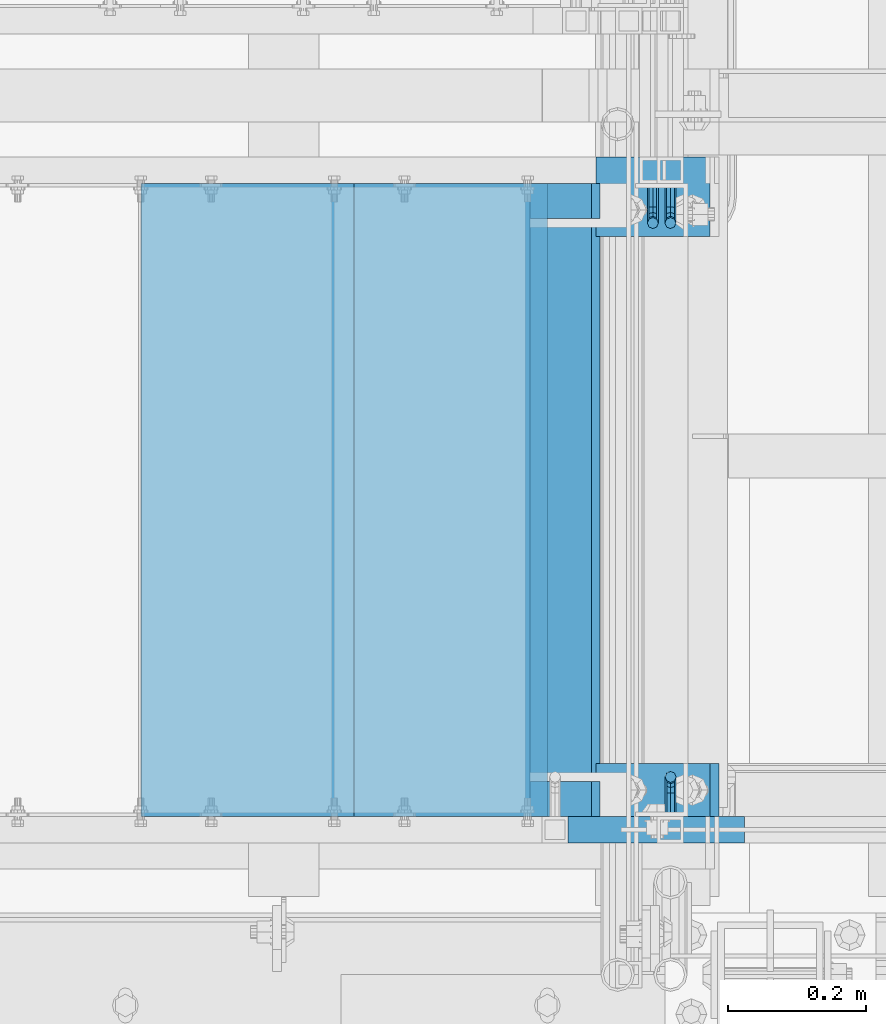
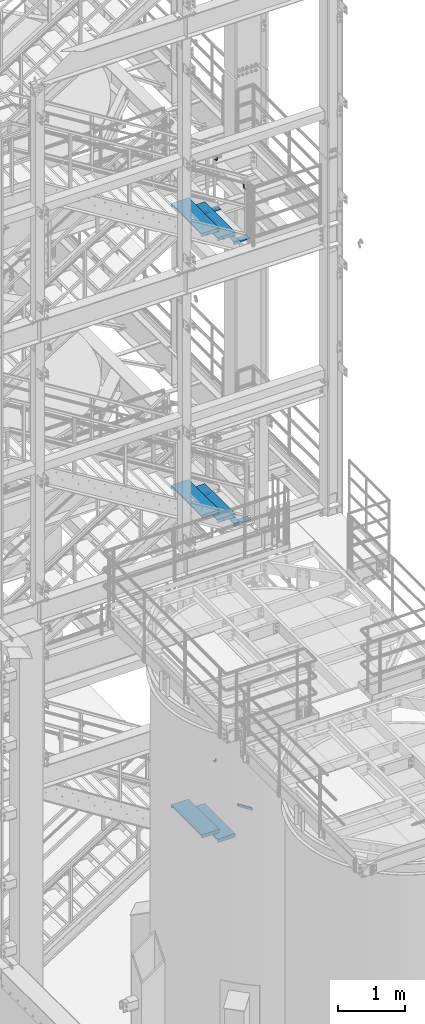
# One storey, part 1155 of 1876: 18 beams, 1 member, 7 elements without a shape of their own.
"""IFC2X3 building model written with IfcOpenShell, lengths in millimetres."""

from ifc_helpers import new_model, si_unit, frame, origin_with_axes, place, context, subcontext, project, spatial, faceted_brep, material, type_object, element, aggregate, save


model = new_model("IFC2X3")

# Units and contexts
model_context = context("Model", 3, precision=1e-05, world=origin_with_axes())
body_context = subcontext(model_context, "Body", "Model", "MODEL_VIEW")
ifc_project = project(units=[si_unit("LENGTHUNIT", "METRE", prefix="MILLI"), si_unit("AREAUNIT", "SQUARE_METRE"), si_unit("VOLUMEUNIT", "CUBIC_METRE"), si_unit("MASSUNIT", "GRAM", prefix="KILO"), si_unit("TIMEUNIT", "SECOND"), si_unit("PLANEANGLEUNIT", "RADIAN"), si_unit("SOLIDANGLEUNIT", "STERADIAN"), si_unit("THERMODYNAMICTEMPERATUREUNIT", "DEGREE_CELSIUS"), si_unit("LUMINOUSINTENSITYUNIT", "LUMEN")], contexts=[model_context])

# Site, building, storey
site_placement = place(None, origin_with_axes())
site = spatial("IfcSite", under=ifc_project, at=site_placement, CompositionType="ELEMENT")
building_placement = place(site_placement, origin_with_axes())
building = spatial("IfcBuilding", under=site, at=building_placement, Name="Undefined", CompositionType="ELEMENT")
storey_placement = place(building_placement, origin_with_axes())
storey = spatial("IfcBuildingStorey", under=building, at=storey_placement, Name="Undefined", CompositionType="ELEMENT", Elevation=0.0)

# Assembly, beam
assembly_1_placement = place(storey_placement, origin_with_axes())
assembly_1 = element("IfcElementAssembly", 1, at=assembly_1_placement, inside=storey, Name="STRINGER", AssemblyPlace="NOTDEFINED", PredefinedType="RIGID_FRAME")
ifc_material_1 = material(Name="STEEL/A36")
beam_type_1 = type_object("IfcBeamType", PredefinedType="NOTDEFINED")
beam_1_placement = place(assembly_1_placement, frame((6121.39999694572, -5975.34987682352, 8159.75000058556), z_axis=(-1.0, 0.0, 0.0), x_axis=(0.0, -1.0, 0.0)))
beam_1 = element("IfcBeam", 2, at=beam_1_placement, type_object=beam_type_1, material=ifc_material_1, Name="PLATE", context=body_context, shape_type="Brep", body=[
    faceted_brep([(0.0, 3.17500000000018, -50.8000000000002), (0.0, 3.17500000000018, 50.8000000000002), (901.700000190736, 3.17500000000018, 50.8000000000002), (901.700000190736, 3.17500000000018, -50.8000000000002), (0.0, -3.17500000000018, 50.8000000000002), (901.700000190736, -3.17500000000018, 50.8000000000002), (0.0, -3.17500000000018, -50.8000000000002), (901.700000190736, -3.17500000000018, -50.8000000000002)], [[[0, 1, 2, 3]], [[1, 4, 5, 2]], [[4, 6, 7, 5]], [[6, 0, 3, 7]], [[5, 7, 3, 2]], [[6, 4, 1, 0]]]),
])

assembly_2_placement = place(storey_placement, origin_with_axes())
assembly_2 = element("IfcElementAssembly", 3, at=assembly_2_placement, inside=storey, Name="RAIL", AssemblyPlace="NOTDEFINED", PredefinedType="RIGID_FRAME")
beam_type_2 = type_object("IfcBeamType", PredefinedType="NOTDEFINED")
beam_2_placement = place(assembly_2_placement, frame((6273.79999407512, -5969.00000114554, 14207.5691203889), z_axis=(-1.0, 0.0, 0.0), x_axis=(0.0, -1.0, 0.0)))
beam_2 = element("IfcBeam", 4, at=beam_2_placement, type_object=beam_type_2, material=ifc_material_1, Name="BRACKET", context=body_context, shape_type="Brep", body=[
    faceted_brep([(0.0, -5.61266007566822, 5.61266007566883), (0.0, 0.0, 7.9375), (0.0, 5.61266007566822, 5.61266007566883), (0.0, 7.9375, 0.0), (0.0, 5.61266007566822, -5.61266007566883), (0.0, 0.0, -7.9375), (0.0, -5.61266007566822, -5.61266007566883), (0.0, -7.9375, 0.0), (23.8125, -5.61266007566883, -5.61266007566792), (23.8125, -7.9375, 0.0), (23.8125, -5.61266007566883, 5.61266007566792), (23.8125, 0.0, 7.9375), (23.8125, 5.61266007566883, 5.61266007566792), (23.8125, 7.9375, 0.0), (23.8125, 5.61266007566883, -5.61266007566792), (23.8125, 0.0, -7.9375), (36.5702095103998, 2.53766620105671, -7.9375), (38.7180815328556, -2.64775556579843, -5.61266007566792), (39.6077592547981, -4.79562758825341, 0.0), (38.7180815328556, -2.64775556579843, 5.61266007566792), (36.5702095103998, 2.53766620105671, 7.9375), (34.4223374879448, 7.72308796790821, 5.61266007566792), (33.5326597660023, 9.87095999036319, 0.0), (34.4223374879448, 7.72308796790821, -5.61266007566792), (43.4169233967659, 13.733078129113, -5.61266007566792), (47.3856733967659, 9.76432812911298, -7.9375), (41.773013321098, 15.3769882047818, 0.0), (43.4169233967659, 13.733078129113, 5.61266007566792), (47.3856733967659, 9.76432812911298, 7.9375), (51.3544233967659, 5.79557812911298, 5.61266007566792), (52.9983334724348, 4.15166805344415, 0.0), (51.3544233967659, 5.79557812911298, -5.61266007566792), (54.6123353248231, 20.5797920154801, -7.9375), (59.7977570916764, 18.4319199930251, -5.61266007566792), (49.4269135579698, 22.727664037935, -5.61266007566792), (47.2790415355148, 23.6173417598766, 0.0), (49.4269135579698, 22.727664037935, 5.61266007566792), (54.6123353248231, 20.5797920154801, 7.9375), (59.7977570916764, 18.4319199930251, 5.61266007566792), (61.9456291141314, 17.5422422710835, 0.0), (62.7626616015468, 33.3375015258789, -5.61266007566792), (65.0875015258789, 33.3375015258789, 0.0), (57.1500015258789, 33.3375015258789, -7.9375), (51.5373414502101, 33.3375015258789, -5.61266007566792), (49.2125015258789, 33.3375015258789, 0.0), (51.5373414502101, 33.3375015258789, 5.61266007566792), (57.1500015258789, 33.3375015258789, 7.9375), (62.7626616015468, 33.3375015258789, 5.61266007566792), (65.0875015258789, 66.5774551740215, 0.0), (62.7626616015468, 70.0546586046949, 5.61266007566792), (57.1500015258789, 71.4949634248096, 7.9375), (51.537341450211, 70.0546586046949, 5.61266007566792), (49.2125015258789, 66.5774551740215, 0.0), (51.537341450211, 63.1002517433481, -5.61266007566792), (57.1500015258789, 61.6599469232333, -7.9375), (62.7626616015468, 63.1002517433481, -5.61266007566792)], [[[0, 1, 2, 3, 4, 5, 6, 7]], [[7, 6, 8, 9]], [[0, 7, 9, 10]], [[1, 0, 10, 11]], [[2, 1, 11, 12]], [[3, 2, 12, 13]], [[4, 3, 13, 14]], [[5, 4, 14, 15]], [[6, 5, 15, 8]], [[8, 15, 16, 17]], [[9, 8, 17, 18]], [[10, 9, 18, 19]], [[11, 10, 19, 20]], [[12, 11, 20, 21]], [[13, 12, 21, 22]], [[14, 13, 22, 23]], [[15, 14, 23, 16]], [[23, 24, 25, 16]], [[22, 26, 24, 23]], [[21, 27, 26, 22]], [[20, 28, 27, 21]], [[19, 29, 28, 20]], [[18, 30, 29, 19]], [[17, 31, 30, 18]], [[16, 25, 31, 17]], [[25, 32, 33, 31]], [[24, 34, 32, 25]], [[26, 35, 34, 24]], [[27, 36, 35, 26]], [[28, 37, 36, 27]], [[29, 38, 37, 28]], [[30, 39, 38, 29]], [[31, 33, 39, 30]], [[33, 40, 41, 39]], [[32, 42, 40, 33]], [[34, 43, 42, 32]], [[35, 44, 43, 34]], [[36, 45, 44, 35]], [[37, 46, 45, 36]], [[38, 47, 46, 37]], [[39, 41, 47, 38]], [[47, 41, 48, 49]], [[46, 47, 49, 50]], [[45, 46, 50, 51]], [[44, 45, 51, 52]], [[43, 44, 52, 53]], [[42, 43, 53, 54]], [[40, 42, 54, 55]], [[41, 40, 55, 48]], [[54, 53, 52, 51, 50, 49, 48, 55]]]),
])
aggregate(assembly_2, [beam_2])

assembly_3_placement = place(storey_placement, origin_with_axes())
assembly_3 = element("IfcElementAssembly", 5, at=assembly_3_placement, inside=storey, Name="RAIL", AssemblyPlace="NOTDEFINED", PredefinedType="RIGID_FRAME")
beam_3_placement = place(assembly_3_placement, frame((6274.09400816551, -6883.39999885446, 14207.3869476422), z_axis=(-1.0, 0.0, 0.0), x_axis=(0.0, 1.0, 0.0)))
beam_3 = element("IfcBeam", 6, at=beam_3_placement, type_object=beam_type_2, material=ifc_material_1, Name="BRACKET", context=body_context, shape_type="Brep", body=[
    faceted_brep([(0.0, -5.61266007566822, 5.61266007566883), (0.0, 0.0, 7.9375), (0.0, 5.61266007566822, 5.61266007566883), (0.0, 7.9375, 0.0), (0.0, 5.61266007566822, -5.61266007566883), (0.0, 0.0, -7.9375), (0.0, -5.61266007566822, -5.61266007566883), (0.0, -7.9375, 0.0), (23.8125, 5.61266007566883, 5.61266007566792), (23.8125, 7.9375, 0.0), (23.8125, 5.61266007566883, -5.61266007566792), (23.8125, 0.0, -7.9375), (23.8125, -5.61266007566883, -5.61266007566792), (23.8125, -7.9375, 0.0), (23.8125, -5.61266007566883, 5.61266007566792), (23.8125, 0.0, 7.9375), (36.5702095103989, -2.53766620105534, 7.9375), (38.7180815328547, 2.64775556579752, 5.61266007566792), (39.6077592547972, 4.79562758825296, 0.0), (38.7180815328547, 2.64775556579752, -5.61266007566792), (36.5702095103989, -2.53766620105534, -7.9375), (34.4223374879439, -7.72308796790867, -5.61266007566792), (33.5326597660014, -9.87095999036364, 0.0), (34.4223374879439, -7.72308796790867, 5.61266007566792), (43.4169233967659, -13.733078129113, 5.61266007566792), (47.385673396765, -9.76432812911298, 7.9375), (41.7730133210971, -15.3769882047809, 0.0), (43.4169233967659, -13.733078129113, -5.61266007566792), (47.385673396765, -9.76432812911298, -7.9375), (51.354423396765, -5.79557812911253, -5.61266007566792), (52.9983334724338, -4.15166805344461, 0.0), (51.354423396765, -5.79557812911253, 5.61266007566792), (54.6123353248231, -20.5797920154787, 7.9375), (59.7977570916764, -18.4319199930233, 5.61266007566792), (49.4269135579698, -22.7276640379341, 5.61266007566792), (47.2790415355148, -23.6173417598766, 0.0), (49.4269135579698, -22.7276640379341, -5.61266007566792), (54.6123353248231, -20.5797920154787, -7.9375), (59.7977570916764, -18.4319199930233, -5.61266007566792), (61.9456291141314, -17.5422422710808, 0.0), (62.7626616015468, -33.3375015258789, 5.61266007566792), (65.0875015258789, -33.3375015258789, 0.0), (57.1500015258789, -33.3375015258789, 7.9375), (51.5373414502101, -33.3375015258789, 5.61266007566792), (49.2125015258789, -33.3375015258789, 0.0), (51.5373414502101, -33.3375015258789, -5.61266007566792), (57.1500015258789, -33.3375015258789, -7.9375), (62.7626616015468, -33.3375015258789, -5.61266007566792), (65.0875015258789, -66.4903966648035, 0.0), (62.7626616015468, -63.0131930011103, -5.61266007566792), (57.1500015258789, -61.5728880844745, -7.9375), (51.537341450211, -63.0131930011103, -5.61266007566792), (49.2125015258789, -66.4903966648035, 0.0), (51.537341450211, -69.9676003284985, 5.61266007566792), (57.1500015258789, -71.4079052451343, 7.9375), (62.7626616015468, -69.9676003284985, 5.61266007566792)], [[[0, 1, 2, 3, 4, 5, 6, 7]], [[3, 2, 8, 9]], [[4, 3, 9, 10]], [[5, 4, 10, 11]], [[6, 5, 11, 12]], [[7, 6, 12, 13]], [[0, 7, 13, 14]], [[1, 0, 14, 15]], [[2, 1, 15, 8]], [[8, 15, 16, 17]], [[9, 8, 17, 18]], [[10, 9, 18, 19]], [[11, 10, 19, 20]], [[12, 11, 20, 21]], [[13, 12, 21, 22]], [[14, 13, 22, 23]], [[15, 14, 23, 16]], [[23, 24, 25, 16]], [[22, 26, 24, 23]], [[21, 27, 26, 22]], [[20, 28, 27, 21]], [[19, 29, 28, 20]], [[18, 30, 29, 19]], [[17, 31, 30, 18]], [[16, 25, 31, 17]], [[25, 32, 33, 31]], [[24, 34, 32, 25]], [[26, 35, 34, 24]], [[27, 36, 35, 26]], [[28, 37, 36, 27]], [[29, 38, 37, 28]], [[30, 39, 38, 29]], [[31, 33, 39, 30]], [[33, 40, 41, 39]], [[32, 42, 40, 33]], [[34, 43, 42, 32]], [[35, 44, 43, 34]], [[36, 45, 44, 35]], [[37, 46, 45, 36]], [[38, 47, 46, 37]], [[39, 41, 47, 38]], [[47, 41, 48, 49]], [[46, 47, 49, 50]], [[45, 46, 50, 51]], [[44, 45, 51, 52]], [[43, 44, 52, 53]], [[42, 43, 53, 54]], [[40, 42, 54, 55]], [[41, 40, 55, 48]], [[54, 53, 52, 51, 50, 49, 48, 55]]]),
])
aggregate(assembly_3, [beam_3])

assembly_4_placement = place(storey_placement, origin_with_axes())
assembly_4 = element("IfcElementAssembly", 7, at=assembly_4_placement, inside=storey, Name="RAIL", AssemblyPlace="NOTDEFINED", PredefinedType="RIGID_FRAME")
beam_4_placement = place(assembly_4_placement, frame((6248.40000001548, -5969.00000106773, 3209.33697701042), z_axis=(-1.0, 0.0, 0.0), x_axis=(0.0, -1.0, 0.0)))
beam_4 = element("IfcBeam", 8, at=beam_4_placement, type_object=beam_type_2, material=ifc_material_1, Name="BRACKET", context=body_context, shape_type="Brep", body=[
    faceted_brep([(0.0, -5.61266007566822, 5.61266007566883), (0.0, 0.0, 7.9375), (0.0, 5.61266007566822, 5.61266007566883), (0.0, 7.9375, 0.0), (0.0, 5.61266007566822, -5.61266007566883), (0.0, 0.0, -7.9375), (0.0, -5.61266007566822, -5.61266007566883), (0.0, -7.9375, 0.0), (23.8125, -5.61266007566883, -5.61266007566792), (23.8125, -7.9375, 0.0), (23.8125, -5.61266007566883, 5.61266007566792), (23.8125, 0.0, 7.9375), (23.8125, 5.61266007566883, 5.61266007566792), (23.8125, 7.9375, 0.0), (23.8125, 5.61266007566883, -5.61266007566792), (23.8125, 0.0, -7.9375), (36.5702095103998, 2.53766620105671, -7.9375), (38.7180815328556, -2.64775556579843, -5.61266007566792), (39.6077592547981, -4.79562758825341, 0.0), (38.7180815328556, -2.64775556579843, 5.61266007566792), (36.5702095103998, 2.53766620105671, 7.9375), (34.4223374879448, 7.72308796790821, 5.61266007566792), (33.5326597660023, 9.87095999036319, 0.0), (34.4223374879448, 7.72308796790821, -5.61266007566792), (43.4169233967659, 13.733078129113, -5.61266007566792), (47.3856733967659, 9.76432812911298, -7.9375), (41.773013321098, 15.3769882047818, 0.0), (43.4169233967659, 13.733078129113, 5.61266007566792), (47.3856733967659, 9.76432812911298, 7.9375), (51.3544233967659, 5.79557812911298, 5.61266007566792), (52.9983334724348, 4.15166805344415, 0.0), (51.3544233967659, 5.79557812911298, -5.61266007566792), (54.6123353248231, 20.5797920154801, -7.9375), (59.7977570916764, 18.4319199930251, -5.61266007566792), (49.4269135579698, 22.727664037935, -5.61266007566792), (47.2790415355148, 23.6173417598766, 0.0), (49.4269135579698, 22.727664037935, 5.61266007566792), (54.6123353248231, 20.5797920154801, 7.9375), (59.7977570916764, 18.4319199930251, 5.61266007566792), (61.9456291141314, 17.5422422710835, 0.0), (62.7626616015468, 33.3375015258789, -5.61266007566792), (65.0875015258789, 33.3375015258789, 0.0), (57.1500015258789, 33.3375015258789, -7.9375), (51.5373414502101, 33.3375015258789, -5.61266007566792), (49.2125015258789, 33.3375015258789, 0.0), (51.5373414502101, 33.3375015258789, 5.61266007566792), (57.1500015258789, 33.3375015258789, 7.9375), (62.7626616015468, 33.3375015258789, 5.61266007566792), (65.0875015258789, 67.3558732176816, 0.0), (62.7626616015468, 70.9165696288755, 5.61266007566837), (57.1500015258789, 72.3914583738861, 7.9375), (51.537341450211, 70.9165696288755, 5.61266007566837), (49.2125015258789, 67.3558732176816, 0.0), (51.537341450211, 63.7951768064877, -5.61266007566837), (57.1500015258789, 62.3202880614781, -7.9375), (62.7626616015468, 63.7951768064877, -5.61266007566837)], [[[0, 1, 2, 3, 4, 5, 6, 7]], [[7, 6, 8, 9]], [[0, 7, 9, 10]], [[1, 0, 10, 11]], [[2, 1, 11, 12]], [[3, 2, 12, 13]], [[4, 3, 13, 14]], [[5, 4, 14, 15]], [[6, 5, 15, 8]], [[8, 15, 16, 17]], [[9, 8, 17, 18]], [[10, 9, 18, 19]], [[11, 10, 19, 20]], [[12, 11, 20, 21]], [[13, 12, 21, 22]], [[14, 13, 22, 23]], [[15, 14, 23, 16]], [[23, 24, 25, 16]], [[22, 26, 24, 23]], [[21, 27, 26, 22]], [[20, 28, 27, 21]], [[19, 29, 28, 20]], [[18, 30, 29, 19]], [[17, 31, 30, 18]], [[16, 25, 31, 17]], [[25, 32, 33, 31]], [[24, 34, 32, 25]], [[26, 35, 34, 24]], [[27, 36, 35, 26]], [[28, 37, 36, 27]], [[29, 38, 37, 28]], [[30, 39, 38, 29]], [[31, 33, 39, 30]], [[33, 40, 41, 39]], [[32, 42, 40, 33]], [[34, 43, 42, 32]], [[35, 44, 43, 34]], [[36, 45, 44, 35]], [[37, 46, 45, 36]], [[38, 47, 46, 37]], [[39, 41, 47, 38]], [[47, 41, 48, 49]], [[46, 47, 49, 50]], [[45, 46, 50, 51]], [[44, 45, 51, 52]], [[43, 44, 52, 53]], [[42, 43, 53, 54]], [[40, 42, 54, 55]], [[41, 40, 55, 48]], [[54, 53, 52, 51, 50, 49, 48, 55]]]),
])
aggregate(assembly_4, [beam_4])

# Assembly, member
assembly_5_placement = place(storey_placement, origin_with_axes())
assembly_5 = element("IfcElementAssembly", 9, at=assembly_5_placement, inside=storey, Name="RAIL", AssemblyPlace="NOTDEFINED", PredefinedType="RIGID_FRAME")
ifc_material_2 = material()
member_type = type_object("IfcMemberType", Name="HSS1-1/2X1-1/2X1/8", PredefinedType="NOTDEFINED")
member_placement = place(assembly_5_placement, frame((6375.4000006161, -6902.45000114554, 2847.20862061102), z_axis=(0.535697420207059, 0.0, 0.844410015326383), x_axis=(-0.844410015326383, 0.0, 0.535697420207059)))
member = element("IfcMember", 10, at=member_placement, type_object=member_type, material=ifc_material_2, Name="RAIL", ObjectType="HSS1-1/2X1-1/2X1/8", context=body_context, shape_type="Brep", body=[
    faceted_brep([(-4.61079482035893, 15.8749992829999, -15.8749992830034), (-4.61079482035893, -15.8749992829999, -15.8749992830034), (285.090536141967, -15.8749992829999, -15.8749992830126), (285.090536141967, 15.8749992829999, -15.8749992830126), (4.61079481841625, -15.8749992829999, 15.8749992830026), (305.23287463446, -15.8749992829999, 15.8749992829826), (4.61079481841625, 15.8749992829999, 15.8749992830026), (305.23287463446, 15.8749992829999, 15.8749992829826), (-5.53295381194494, 19.0499992349996, -19.0499992350046), (5.53295381000225, 19.0499992349996, 19.0499992350038), (307.24710854423, 19.0499992349996, 19.0499992349824), (283.076302232195, 19.0499992349996, -19.0499992350115), (5.53295381000225, -19.0499992349996, 19.0499992350038), (307.24710854423, -19.0499992349996, 19.0499992349824), (-5.53295381194494, -19.0499992349996, -19.0499992350046), (283.076302232195, -19.0499992349996, -19.0499992350115)], [[[0, 1, 2, 3]], [[1, 4, 5, 2]], [[4, 6, 7, 5]], [[6, 0, 3, 7]], [[8, 9, 10, 11]], [[9, 12, 13, 10]], [[12, 14, 15, 13]], [[14, 8, 11, 15]], [[13, 15, 11, 10], [5, 7, 3, 2]], [[14, 12, 9, 8], [6, 4, 1, 0]]]),
])
aggregate(assembly_5, [member])

# Assembly, beams
assembly_6_placement = place(storey_placement, origin_with_axes())
assembly_6 = element("IfcElementAssembly", 11, at=assembly_6_placement, inside=storey, Name="STRINGER", AssemblyPlace="NOTDEFINED", PredefinedType="RIGID_FRAME")
beam_type_3 = type_object("IfcBeamType", PredefinedType="NOTDEFINED")
beam_5_placement = place(assembly_6_placement, frame((5662.61250054129, -5973.763001146, 13655.792592593), z_axis=(1.0, 0.0, 0.0), x_axis=(0.0, -1.0, 0.0)))
beam_5 = element("IfcBeam", 12, at=beam_5_placement, type_object=beam_type_3, material=ifc_material_1, Name="TREAD", context=body_context, shape_type="Brep", body=[
    faceted_brep([(-7.45785655453801e-11, 53.9750000000167, -153.9875), (-7.45785655453801e-11, 53.9750000000167, 153.987506103515), (0.0, 9.52499999999964, 153.9875), (-7.45785655453801e-11, 9.52499999999964, -153.9875), (-4.76300000007541, 53.9750000000167, -153.9875), (-4.76300000007541, 53.9750000000167, 153.987506103515), (-4.76300000007541, -9.52499999998327, -153.9875), (-4.76300000007541, -9.52500000019427, 153.987536621094), (909.637000008669, 53.9749999975102, 153.987506103515), (904.87400000867, 53.9749999975102, 153.987506103515), (904.87400000867, 9.52499999999964, 153.987506103515), (909.637000008669, -9.52500000248983, 153.987506103515), (904.87400000867, 9.52499999999964, -153.9875), (909.637000008669, -9.52500000248983, -153.9875), (909.637000008669, 53.9749999975102, -153.9875), (904.87400000867, 53.9749999975102, -153.9875)], [[[0, 1, 2, 3]], [[1, 0, 4, 5]], [[5, 4, 6, 7]], [[8, 9, 10, 2, 1, 5, 7, 11]], [[12, 3, 2, 10]], [[13, 11, 7, 6]], [[8, 14, 15, 9]], [[14, 8, 11, 13]], [[14, 13, 6, 4, 0, 3, 12, 15]], [[9, 15, 12, 10]]]),
])
beam_6_placement = place(assembly_6_placement, frame((5942.01250046289, -5973.76300114588, 13482.6962962967), z_axis=(1.0, 0.0, 0.0), x_axis=(0.0, -1.0, 0.0)))
beam_6 = element("IfcBeam", 13, at=beam_6_placement, type_object=beam_type_3, material=ifc_material_1, Name="TREAD", context=body_context, shape_type="Brep", body=[
    faceted_brep([(-7.45785655453801e-11, 53.9750000000167, -153.9875), (-7.45785655453801e-11, 53.9750000000167, 153.987506103515), (0.0, 9.52499999999964, 153.9875), (-7.45785655453801e-11, 9.52499999999964, -153.9875), (-4.76300000007541, 53.9750000000167, -153.9875), (-4.76300000007541, 53.9750000000167, 153.987506103515), (-4.76300000007541, -9.52499999998327, -153.9875), (-4.76300000007541, -9.52500000019427, 153.987536621094), (909.637000008669, -9.52500000248983, 153.987506103515), (909.637000008669, 53.9749999975102, 153.987506103515), (904.87400000867, 53.9749999975102, 153.987506103515), (904.87400000867, 9.52499999999964, 153.987506103515), (-7.45785655453801e-11, -9.52500000019427, 153.987536621094), (904.87400000867, -9.52500000248983, 153.987506103515), (904.87400000867, 9.52499999999964, -153.9875), (909.637000008669, -9.52500000248983, -153.9875), (909.637000008669, 53.9749999975102, -153.9875), (904.87400000867, 53.9749999975102, -153.9875)], [[[0, 1, 2, 3]], [[1, 0, 4, 5]], [[5, 4, 6, 7]], [[8, 9, 10, 11, 2, 1, 5, 7, 12, 13]], [[14, 3, 2, 11]], [[15, 8, 13, 12, 7, 6]], [[9, 16, 17, 10]], [[16, 9, 8, 15]], [[16, 15, 6, 4, 0, 3, 14, 17]], [[10, 17, 14, 11]]]),
])

# Beam
beam_7_placement = place(assembly_1_placement, frame((5662.61250038542, -5973.76300114698, 8497.14666679598), z_axis=(1.0, 0.0, 0.0), x_axis=(0.0, -1.0, 0.0)))
beam_7 = element("IfcBeam", 14, at=beam_7_placement, type_object=beam_type_3, material=ifc_material_1, Name="TREAD", context=body_context, shape_type="Brep", body=[
    faceted_brep([(-7.45785655453801e-11, 53.9750000000167, -153.9875), (-7.45785655453801e-11, 53.9750000000167, 153.987506103515), (0.0, 9.52499999999964, 153.9875), (-7.45785655453801e-11, 9.52499999999964, -153.9875), (-4.76300000007541, 53.9750000000167, -153.9875), (-4.76300000007541, 53.9750000000167, 153.987506103515), (-4.76300000007541, -9.52499999998327, -153.9875), (-4.76300000007541, -9.52500000019427, 153.987536621094), (909.637000008669, -9.52500000248983, 153.987506103515), (909.637000008669, 53.9749999975102, 153.987506103515), (904.87400000867, 53.9749999975102, 153.987506103515), (904.87400000867, 9.52499999999964, 153.987506103515), (-7.45785655453801e-11, -9.52500000019427, 153.987536621094), (904.87400000867, -9.52500000248983, 153.987506103515), (904.87400000867, 9.52499999999964, -153.9875), (909.637000008669, -9.52500000248983, -153.9875), (909.637000008669, 53.9749999975102, -153.9875), (904.87400000867, 53.9749999975102, -153.9875)], [[[0, 1, 2, 3]], [[1, 0, 4, 5]], [[5, 4, 6, 7]], [[8, 9, 10, 11, 2, 1, 5, 7, 12, 13]], [[14, 3, 2, 11]], [[15, 8, 13, 12, 7, 6]], [[9, 16, 17, 10]], [[16, 9, 8, 15]], [[16, 15, 6, 4, 0, 3, 14, 17]], [[10, 17, 14, 11]]]),
])

beam_8_placement = place(assembly_1_placement, frame((5942.01250031588, -5973.76300114724, 8325.27333339879), z_axis=(1.0, 0.0, 0.0), x_axis=(0.0, -1.0, 0.0)))
beam_8 = element("IfcBeam", 15, at=beam_8_placement, type_object=beam_type_3, material=ifc_material_1, Name="TREAD", context=body_context, shape_type="Brep", body=[
    faceted_brep([(-7.45785655453801e-11, 53.9750000000167, -153.9875), (-7.45785655453801e-11, 53.9750000000167, 153.987506103515), (0.0, 9.52499999999964, 153.9875), (-7.45785655453801e-11, 9.52499999999964, -153.9875), (-4.76300000007541, 53.9750000000167, -153.9875), (-4.76300000007541, 53.9750000000167, 153.987506103515), (-4.76300000007541, -9.52499999998327, -153.9875), (-4.76300000007541, -9.52500000019427, 153.987536621094), (909.637000008669, -9.52500000248983, 153.987506103515), (909.637000008669, 53.9749999975102, 153.987506103515), (904.87400000867, 53.9749999975102, 153.987506103515), (904.87400000867, 9.52499999999964, 153.987506103515), (-7.45785655453801e-11, -9.52500000019427, 153.987536621094), (904.87400000867, -9.52500000248983, 153.987506103515), (904.87400000867, 9.52499999999964, -153.9875), (909.637000008669, -9.52500000248983, -153.9875), (909.637000008669, 53.9749999975102, -153.9875), (904.87400000867, 53.9749999975102, -153.9875)], [[[0, 1, 2, 3]], [[1, 0, 4, 5]], [[5, 4, 6, 7]], [[8, 9, 10, 11, 2, 1, 5, 7, 12, 13]], [[14, 3, 2, 11]], [[15, 8, 13, 12, 7, 6]], [[9, 16, 17, 10]], [[16, 9, 8, 15]], [[16, 15, 6, 4, 0, 3, 14, 17]], [[10, 17, 14, 11]]]),
])

# Assembly, beams
assembly_7_placement = place(storey_placement, origin_with_axes())
assembly_7 = element("IfcElementAssembly", 16, at=assembly_7_placement, inside=storey, Name="STRINGER", AssemblyPlace="NOTDEFINED", PredefinedType="RIGID_FRAME")
beam_9_placement = place(assembly_7_placement, frame((5662.6125016581, -5973.76300113212, 2649.26379310871), z_axis=(1.0, 0.0, 0.0), x_axis=(0.0, -1.0, 0.0)))
beam_9 = element("IfcBeam", 17, at=beam_9_placement, type_object=beam_type_3, material=ifc_material_1, Name="TREAD", context=body_context, shape_type="Brep", body=[
    faceted_brep([(-7.45785655453801e-11, 53.9750000000167, -153.9875), (-7.45785655453801e-11, 53.9750000000167, 153.987506103515), (0.0, 9.52499999999964, 153.9875), (-7.45785655453801e-11, 9.52499999999964, -153.9875), (-4.76300000007541, 53.9750000000167, -153.9875), (-4.76300000007541, 53.9750000000167, 153.987506103515), (-4.76300000007541, -9.52499999998327, -153.9875), (-4.76300000007541, -9.52500000019427, 153.987536621094), (909.637000008669, -9.52500000248983, 153.987506103515), (909.637000008669, 53.9749999975102, 153.987506103515), (904.87400000867, 53.9749999975102, 153.987506103515), (904.87400000867, 9.52499999999964, 153.987506103515), (-7.45785655453801e-11, -9.52500000019427, 153.987536621094), (904.87400000867, -9.52500000248983, 153.987506103515), (904.87400000867, 9.52499999999964, -153.9875), (909.637000008669, -9.52500000248983, -153.9875), (909.637000008669, 53.9749999975102, -153.9875), (904.87400000867, 53.9749999975102, -153.9875)], [[[0, 1, 2, 3]], [[1, 0, 4, 5]], [[5, 4, 6, 7]], [[8, 9, 10, 11, 2, 1, 5, 7, 12, 13]], [[14, 3, 2, 11]], [[15, 8, 13, 12, 7, 6]], [[9, 16, 17, 10]], [[16, 9, 8, 15]], [[16, 15, 6, 4, 0, 3, 14, 17]], [[10, 17, 14, 11]]]),
])
beam_10_placement = place(assembly_7_placement, frame((5942.0125013403, -5973.76300113196, 2472.01120690207), z_axis=(1.0, 0.0, 0.0), x_axis=(0.0, -1.0, 0.0)))
beam_10 = element("IfcBeam", 18, at=beam_10_placement, type_object=beam_type_3, material=ifc_material_1, Name="TREAD", context=body_context, shape_type="Brep", body=[
    faceted_brep([(-7.45785655453801e-11, 53.9750000000167, -153.9875), (-7.45785655453801e-11, 53.9750000000167, 153.987506103515), (0.0, 9.52499999999964, 153.9875), (-7.45785655453801e-11, 9.52499999999964, -153.9875), (-4.76300000007541, 53.9750000000167, -153.9875), (-4.76300000007541, 53.9750000000167, 153.987506103515), (-4.76300000007541, -9.52499999998327, -153.9875), (-4.76300000007541, -9.52500000019427, 153.987536621094), (909.637000008669, -9.52500000248983, 153.987506103515), (909.637000008669, 53.9749999975102, 153.987506103515), (904.87400000867, 53.9749999975102, 153.987506103515), (904.87400000867, 9.52499999999964, 153.987506103515), (-7.45785655453801e-11, -9.52500000019427, 153.987536621094), (904.87400000867, -9.52500000248983, 153.987506103515), (904.87400000867, 9.52499999999964, -153.9875), (909.637000008669, -9.52500000248983, -153.9875), (909.637000008669, 53.9749999975102, -153.9875), (904.87400000867, 53.9749999975102, -153.9875)], [[[0, 1, 2, 3]], [[1, 0, 4, 5]], [[5, 4, 6, 7]], [[8, 9, 10, 11, 2, 1, 5, 7, 12, 13]], [[14, 3, 2, 11]], [[15, 8, 13, 12, 7, 6]], [[9, 16, 17, 10]], [[16, 9, 8, 15]], [[16, 15, 6, 4, 0, 3, 14, 17]], [[10, 17, 14, 11]]]),
])
aggregate(assembly_7, [beam_9, beam_10])

# Beam
beam_type_4 = type_object("IfcBeamType", Name="L2X2X1/4", PredefinedType="NOTDEFINED")
beam_11_placement = place(assembly_1_placement, frame((6172.19999694572, -6857.9998746567, 8131.17500058556), z_axis=(0.0, 1.0, 0.0), x_axis=(-1.0, 0.0, 0.0)))
beam_11 = element("IfcBeam", 19, at=beam_11_placement, type_object=beam_type_4, material=ifc_material_1, Name="ANGLE", ObjectType="L2X2X1/4", context=body_context, shape_type="Brep", body=[
    faceted_brep([(0.0, 25.3999999999996, -25.3999999999996), (0.0, 25.3999999999996, 25.3999999999996), (101.599999999998, 25.3999999999996, 25.3999999999996), (101.599999999998, 25.3999999999996, -25.3999999999996), (0.0, 19.0500000000002, 25.3999999999996), (101.599999999998, 19.0500000000002, 25.3999999999996), (0.0, 19.0499992349996, -19.0499992350001), (101.599999999998, 19.0500000000002, -19.0500000000002), (0.0, -25.3999999999996, -19.0500000000002), (101.599999999998, -25.3999999999996, -19.0500000000002), (0.0, -25.3999999999996, -25.3999999999996), (101.599999999998, -25.3999999999996, -25.3999999999996)], [[[0, 1, 2, 3]], [[1, 4, 5, 2]], [[4, 6, 7, 5]], [[6, 8, 9, 7]], [[8, 10, 11, 9]], [[10, 0, 3, 11]], [[5, 7, 9, 11, 3, 2]], [[10, 8, 6, 4, 1, 0]]]),
])

beam_12_placement = place(assembly_1_placement, frame((6070.59999998206, -5994.39987691889, 8131.17500058556), z_axis=(0.0, -1.0, 0.0), x_axis=(1.0, 0.0, 0.0)))
beam_12 = element("IfcBeam", 20, at=beam_12_placement, type_object=beam_type_4, material=ifc_material_1, Name="ANGLE", ObjectType="L2X2X1/4", context=body_context, shape_type="Brep", body=[
    faceted_brep([(0.0, 25.3999999999996, -25.3999999999996), (0.0, 25.3999999999996, 25.3999999999996), (101.599999999998, 25.3999999999996, 25.3999999999996), (101.599999999998, 25.3999999999996, -25.3999999999996), (0.0, 19.0500000000002, 25.3999999999996), (101.599999999998, 19.0500000000002, 25.3999999999996), (0.0, 19.0499992349996, -19.0499992350001), (101.599999999998, 19.0500000000002, -19.0500000000002), (0.0, -25.3999999999996, -19.0500000000002), (101.599999999998, -25.3999999999996, -19.0500000000002), (0.0, -25.3999999999996, -25.3999999999996), (101.599999999998, -25.3999999999996, -25.3999999999996)], [[[0, 1, 2, 3]], [[1, 4, 5, 2]], [[4, 6, 7, 5]], [[6, 8, 9, 7]], [[8, 10, 11, 9]], [[10, 0, 3, 11]], [[5, 7, 9, 11, 3, 2]], [[10, 8, 6, 4, 1, 0]]]),
])

beam_13_placement = place(assembly_6_placement, frame((6159.49999995459, -6857.99999888316, 13287.3750005856), z_axis=(0.0, 1.0, 0.0), x_axis=(-1.0, 0.0, 0.0)))
beam_13 = element("IfcBeam", 21, at=beam_13_placement, type_object=beam_type_4, material=ifc_material_1, Name="ANGLE", ObjectType="L2X2X1/4", context=body_context, shape_type="Brep", body=[
    faceted_brep([(0.0, 25.3999999999996, -25.3999999999996), (0.0, 25.3999999999996, 25.3999999999996), (88.8999999999978, 25.3999999999996, 25.3999999999996), (88.8999999999978, 25.3999999999996, -25.3999999999996), (0.0, 19.0500000000002, 25.3999999999996), (88.8999999999978, 19.0499999999993, 25.3999999999996), (0.0, 19.0499992349996, -19.0499992350001), (88.8999999999978, 19.0499999999993, -19.0500000000002), (0.0, -25.3999999999996, -19.0500000000002), (88.8999999999978, -25.3999999999996, -19.0500000000002), (0.0, -25.3999999999996, -25.3999999999996), (88.8999999999978, -25.3999999999996, -25.3999999999996)], [[[0, 1, 2, 3]], [[1, 4, 5, 2]], [[4, 6, 7, 5]], [[6, 8, 9, 7]], [[8, 10, 11, 9]], [[10, 0, 3, 11]], [[5, 7, 9, 11, 3, 2]], [[10, 8, 6, 4, 1, 0]]]),
])

beam_14_placement = place(assembly_6_placement, frame((6070.59999998204, -5994.40000114534, 13287.3750005856), z_axis=(0.0, -1.0, 0.0), x_axis=(1.0, 0.0, 0.0)))
beam_14 = element("IfcBeam", 22, at=beam_14_placement, type_object=beam_type_4, material=ifc_material_1, Name="ANGLE", ObjectType="L2X2X1/4", context=body_context, shape_type="Brep", body=[
    faceted_brep([(0.0, 25.3999999999996, -25.3999999999996), (0.0, 25.3999999999996, 25.3999999999996), (88.8999999999978, 25.3999999999996, 25.3999999999996), (88.8999999999978, 25.3999999999996, -25.3999999999996), (0.0, 19.0500000000002, 25.3999999999996), (88.8999999999978, 19.0499999999993, 25.3999999999996), (0.0, 19.0499992349996, -19.0499992350001), (88.8999999999978, 19.0499999999993, -19.0500000000002), (0.0, -25.3999999999996, -19.0500000000002), (88.8999999999978, -25.3999999999996, -19.0500000000002), (0.0, -25.3999999999996, -25.3999999999996), (88.8999999999978, -25.3999999999996, -25.3999999999996)], [[[0, 1, 2, 3]], [[1, 4, 5, 2]], [[4, 6, 7, 5]], [[6, 8, 9, 7]], [[8, 10, 11, 9]], [[10, 0, 3, 11]], [[5, 7, 9, 11, 3, 2]], [[10, 8, 6, 4, 1, 0]]]),
])

beam_type_5 = type_object("IfcBeamType", PredefinedType="NOTDEFINED")
beam_15_placement = place(assembly_6_placement, frame((6115.04999998204, -5975.35000104997, 13315.9500005856), z_axis=(-1.0, 0.0, 0.0), x_axis=(0.0, -1.0, 0.0)))
beam_15 = element("IfcBeam", 23, at=beam_15_placement, type_object=beam_type_5, material=ifc_material_1, Name="PLATE", context=body_context, shape_type="Brep", body=[
    faceted_brep([(0.0, 3.17499999999927, -44.4499999999998), (0.0, 3.17499999999927, 44.4499999999998), (901.700000190736, 3.17499999999927, 44.4499999999998), (901.700000190736, 3.17499999999927, -44.4499999999998), (0.0, -3.17499999999927, 44.4499999999998), (901.700000190736, -3.17499999999927, 44.4499999999998), (0.0, -3.17499999999927, -44.4499999999998), (901.700000190736, -3.17499999999927, -44.4499999999998)], [[[0, 1, 2, 3]], [[1, 4, 5, 2]], [[4, 6, 7, 5]], [[6, 0, 3, 7]], [[5, 7, 3, 2]], [[6, 4, 1, 0]]]),
])

beam_type_6 = type_object("IfcBeamType", PredefinedType="NOTDEFINED")
beam_16_placement = place(assembly_6_placement, frame((6331.03609316201, -6864.35000113848, 13312.7749999985), z_axis=(0.0, -1.0, 0.0), x_axis=(-1.0, 0.0, 0.0)))
beam_16 = element("IfcBeam", 24, at=beam_16_placement, type_object=beam_type_6, material=ifc_material_1, Name="PLATE", context=body_context, shape_type="Brep", body=[
    faceted_brep([(0.0, 3.17499999999927, -57.1499999999996), (0.0, 3.17499999999927, 57.1499999999996), (165.099999999999, 3.17499999999927, 57.1499999999996), (165.099999999999, 3.17499999999927, -57.1499999999996), (0.0, -3.17499999999927, 57.1499999999996), (165.099999999999, -3.17499999999927, 57.1499999999996), (0.0, -3.17499999999927, -57.1499999999996), (165.099999999999, -3.17499999999927, -57.1499999999996)], [[[0, 1, 2, 3]], [[1, 4, 5, 2]], [[4, 6, 7, 5]], [[6, 0, 3, 7]], [[5, 7, 3, 2]], [[6, 4, 1, 0]]]),
])

beam_17_placement = place(assembly_6_placement, frame((6331.03609316201, -5988.05000114537, 13312.775), z_axis=(0.0, -1.0, 0.0), x_axis=(-1.0, 0.0, 0.0)))
beam_17 = element("IfcBeam", 25, at=beam_17_placement, type_object=beam_type_6, material=ifc_material_1, Name="PLATE", context=body_context, shape_type="Brep", body=[
    faceted_brep([(0.0, 3.17499999999927, -57.1499999999996), (0.0, 3.17499999999927, 57.1499999999996), (165.099999999999, 3.17499999999927, 57.1499999999996), (165.099999999999, 3.17499999999927, -57.1499999999996), (0.0, -3.17499999999927, 57.1499999999996), (165.099999999999, -3.17499999999927, 57.1499999999996), (0.0, -3.17499999999927, -57.1499999999996), (165.099999999999, -3.17499999999927, -57.1499999999996)], [[[0, 1, 2, 3]], [[1, 4, 5, 2]], [[4, 6, 7, 5]], [[6, 0, 3, 7]], [[5, 7, 3, 2]], [[6, 4, 1, 0]]]),
])

aggregate(assembly_6, [beam_5, beam_6, beam_13, beam_14, beam_15, beam_16, beam_17])

beam_18_placement = place(assembly_1_placement, frame((6343.65, -6864.35000113848, 8156.5749999977), z_axis=(0.0, -1.0, 0.0), x_axis=(-1.0, 0.0, 0.0)))
beam_18 = element("IfcBeam", 26, at=beam_18_placement, type_object=beam_type_6, material=ifc_material_1, Name="PLATE", context=body_context, shape_type="Brep", body=[
    faceted_brep([(0.0, 3.17499999999927, -57.1499999999996), (0.0, 3.17499999999927, 57.1499999999996), (165.099999999999, 3.17499999999927, 57.1499999999996), (165.099999999999, 3.17499999999927, -57.1499999999996), (0.0, -3.17499999999927, 57.1499999999996), (165.099999999999, -3.17499999999927, 57.1499999999996), (0.0, -3.17499999999927, -57.1499999999996), (165.099999999999, -3.17499999999927, -57.1499999999996)], [[[0, 1, 2, 3]], [[1, 4, 5, 2]], [[4, 6, 7, 5]], [[6, 0, 3, 7]], [[5, 7, 3, 2]], [[6, 4, 1, 0]]]),
])

aggregate(assembly_1, [beam_7, beam_8, beam_11, beam_12, beam_1, beam_18])

save(model, "model.ifc")
